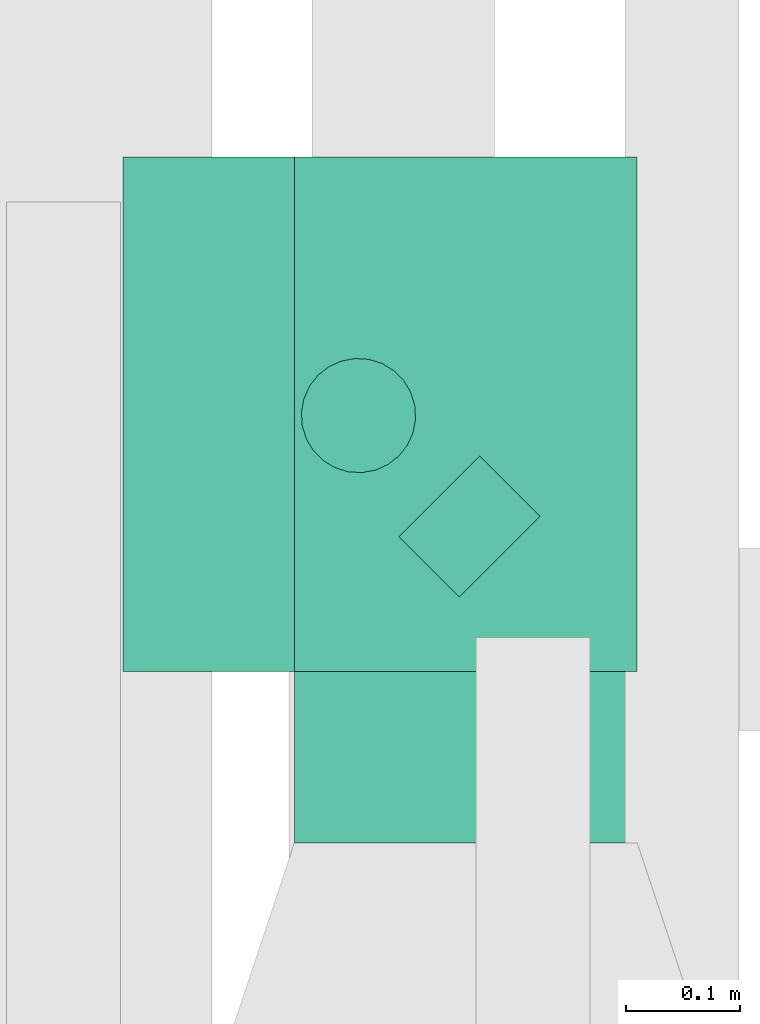
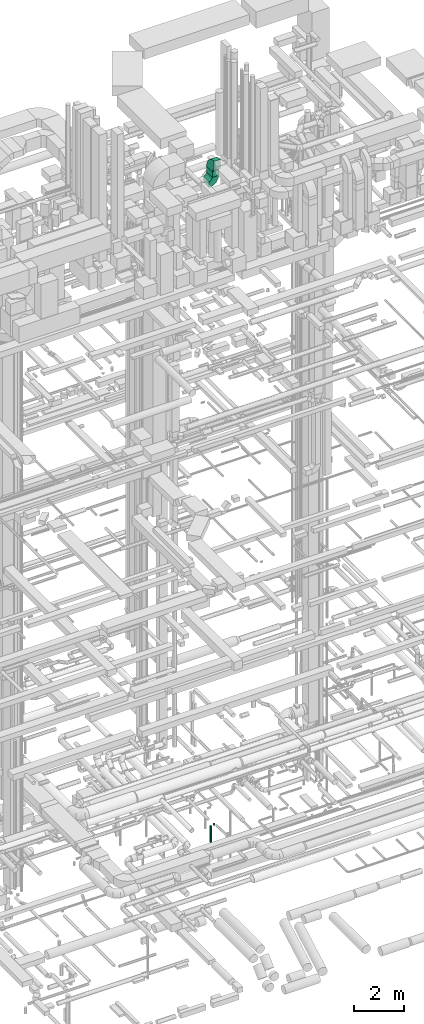
# One storey, part 225 of 337: 3 flow segments, 2 flow fittings.
"""IFC2X3 building model written with IfcOpenShell, lengths in millimetres."""

import ifcopenshell
import ifcopenshell.guid

model = None  # the IFC model being written
_history = None  # IfcOwnerHistory: only IFC2X3 demands one
_inside = {}  # id of a spatial element -> (the spatial element, [elements in it])
_under = {}  # id of a project, library or spatial element -> (it, [spatial elements below it])
_declared = {}  # id of a project -> (the project, [libraries it declares])
_typed = {}  # id of a type object -> (the type object, [elements of that type])
_made_of = {}  # id of a material, layer set ... -> (it, [elements and type objects made of it])


def new_model(schema):
    """Start an empty IFC model of exactly this schema.

    Asked for "IFC4X3", IfcOpenShell would pick the latest addendum, in which some entities
    have other attributes; the version numbers below select the first issue.
    IFC2X3 requires an IfcOwnerHistory on every rooted entity: one is made here for all.
    """
    global model, _history
    if schema == "IFC4X3":
        model = ifcopenshell.file(schema_version=(4, 3, 0, 0))
    else:
        model = ifcopenshell.file(schema=schema)
    _inside.clear()
    _under.clear()
    _declared.clear()
    _typed.clear()
    _made_of.clear()
    _history = None
    if model.schema == "IFC2X3":
        org = make("IfcOrganization", Name="unknown")
        user = make(
            "IfcPersonAndOrganization",
            ThePerson=make("IfcPerson", FamilyName="unknown"),
            TheOrganization=org,
        )
        app = make(
            "IfcApplication",
            ApplicationDeveloper=org,
            Version="unknown",
            ApplicationFullName="unknown",
            ApplicationIdentifier="unknown",
        )
        _history = make(
            "IfcOwnerHistory",
            OwningUser=user,
            OwningApplication=app,
            ChangeAction="ADDED",
            CreationDate=0,
        )
    return model


def make(cls, **values):
    """One entity of the class cls with the attributes given. An attribute that is None is left unset."""
    return model.create_entity(
        cls, **{name: value for name, value in values.items() if value is not None}
    )


def entity(cls, *values):
    """Any entity or typed value of the class cls, its attributes in the order of the schema. None: left unset."""
    e = model.create_entity(cls)
    for i, value in enumerate(values):
        if value is not None:
            e[i] = value
    return e


def rooted(cls, **values):
    """An entity with a GlobalId (a new one), such as an element, a storey or a relation."""
    return make(cls, GlobalId=ifcopenshell.guid.new(), OwnerHistory=_history, **values)


def si_unit(unit_type, name, prefix=None):
    """IfcSIUnit, for example si_unit("LENGTHUNIT", "METRE", prefix="MILLI")."""
    return make("IfcSIUnit", UnitType=unit_type, Prefix=prefix, Name=name)


def converted_unit(unit_type, name, factor, base, dimensions=None, offset=None):
    """IfcConversionBasedUnit, such as the inch: factor (a typed value) times the base unit."""
    return make(
        "IfcConversionBasedUnit"
        if offset is None
        else "IfcConversionBasedUnitWithOffset",
        ConversionOffset=offset,
        Dimensions=None
        if dimensions is None
        else entity("IfcDimensionalExponents", *dimensions),
        UnitType=unit_type,
        Name=name,
        ConversionFactor=make(
            "IfcMeasureWithUnit", ValueComponent=factor, UnitComponent=base
        ),
    )


def derived_unit(unit_type, elements):
    """IfcDerivedUnit: a product of units, each with its exponent."""
    return make(
        "IfcDerivedUnit",
        Elements=[
            make("IfcDerivedUnitElement", Unit=unit, Exponent=power)
            for unit, power in elements
        ],
        UnitType=unit_type,
    )


def assignment(units):
    """IfcUnitAssignment: the units of a project."""
    return None if units is None else make("IfcUnitAssignment", Units=units)


def point(xyz):
    """IfcCartesianPoint."""
    return None if xyz is None else make("IfcCartesianPoint", Coordinates=xyz)


def direction(xyz):
    """IfcDirection."""
    return None if xyz is None else make("IfcDirection", DirectionRatios=xyz)


def frame(location, z_axis=None, x_axis=None):
    """IfcAxis2Placement3D, a coordinate frame: its origin and axes. An axis left out is left unset."""
    return make(
        "IfcAxis2Placement3D",
        Location=point(location),
        Axis=direction(z_axis),
        RefDirection=direction(x_axis),
    )


def frame_2d(location, x_axis=None):
    """IfcAxis2Placement2D, a coordinate frame in the plane: its origin and x axis."""
    return make(
        "IfcAxis2Placement2D", Location=point(location), RefDirection=direction(x_axis)
    )


def origin():
    """The frame at (0, 0, 0) with its axes left unset."""
    return frame((0.0, 0.0, 0.0))


def origin_2d_with_axis():
    """The frame at (0, 0) in the plane with the x axis (1, 0) written out."""
    return frame_2d((0.0, 0.0), x_axis=(1.0, 0.0))


def place(relative_to, where):
    """IfcLocalPlacement: puts the frame where relative to a parent placement (None: the world)."""
    return make(
        "IfcLocalPlacement", PlacementRelTo=relative_to, RelativePlacement=where
    )


def context(
    kind, dimensions, precision=None, world=None, true_north=None, identifier=None
):
    """IfcGeometricRepresentationContext, for example the 3D "Model" context."""
    return make(
        "IfcGeometricRepresentationContext",
        ContextIdentifier=identifier,
        ContextType=kind,
        CoordinateSpaceDimension=dimensions,
        Precision=precision,
        WorldCoordinateSystem=world,
        TrueNorth=true_north,
    )


def subcontext(parent, identifier, kind, view, scale=None):
    """IfcGeometricRepresentationSubContext, for example "Body" below "Model"."""
    return make(
        "IfcGeometricRepresentationSubContext",
        ContextIdentifier=identifier,
        ContextType=kind,
        ParentContext=parent,
        TargetScale=scale,
        TargetView=view,
    )


def project(units=None, contexts=None):
    """IfcProject with its units and contexts."""
    return rooted(
        "IfcProject",
        Name="project",
        RepresentationContexts=contexts,
        UnitsInContext=assignment(units),
    )


def spatial(cls, under=None, at=None, **own):
    """A site, building, storey or space (cls), placed at a placement, below another one or the project."""
    s = rooted(cls, ObjectPlacement=at, **own)
    if under is not None:
        _under.setdefault(under.id(), (under, []))[1].append(s)
    return s


def polyline(points):
    """IfcPolyline through the points."""
    return make("IfcPolyline", Points=[point(p) for p in points])


def circle_curve(where, radius):
    """IfcCircle in the frame where."""
    return make("IfcCircle", Position=where, Radius=radius)


def parameter(value):
    """IfcParameterValue: where a trimmed curve begins or ends, as a parameter of its basis curve."""
    return model.create_entity("IfcParameterValue", value)


def trimmed(basis, trim1, trim2, sense, master):
    """IfcTrimmedCurve: the piece of a basis curve between two trims."""
    return make(
        "IfcTrimmedCurve",
        BasisCurve=basis,
        Trim1=trim1,
        Trim2=trim2,
        SenseAgreement=sense,
        MasterRepresentation=master,
    )


def segment(curve, same_sense, transition):
    """IfcCompositeCurveSegment."""
    return make(
        "IfcCompositeCurveSegment",
        Transition=transition,
        SameSense=same_sense,
        ParentCurve=curve,
    )


def composite_curve(segments, self_intersect=None):
    """IfcCompositeCurve: segments joined end to end."""
    return make("IfcCompositeCurve", Segments=segments, SelfIntersect=self_intersect)


def profile(cls, at=None, kind="AREA", **sizes):
    """A parametric profile (cls). Its sizes go by their IFC names, for example OverallWidth=200.0."""
    return make(cls, ProfileType=kind, Position=at, **sizes)


def rectangle(**sizes):
    """IfcRectangleProfileDef."""
    return profile("IfcRectangleProfileDef", **sizes)


def circle(**sizes):
    """IfcCircleProfileDef."""
    return profile("IfcCircleProfileDef", **sizes)


def outline(outer, holes=None, kind="AREA"):
    """IfcArbitraryClosedProfileDef: a profile drawn as a closed curve; with holes, ...WithVoids."""
    if holes is None:
        return make("IfcArbitraryClosedProfileDef", ProfileType=kind, OuterCurve=outer)
    return make(
        "IfcArbitraryProfileDefWithVoids",
        ProfileType=kind,
        OuterCurve=outer,
        InnerCurves=holes,
    )


def extrude(swept, where, along, depth):
    """IfcExtrudedAreaSolid: the profile swept, set in the frame where, extruded along a direction by depth."""
    return make(
        "IfcExtrudedAreaSolid",
        SweptArea=swept,
        Position=where,
        ExtrudedDirection=direction(along),
        Depth=depth,
    )


def shape(context_of_items, identifier, shape_type, items):
    """IfcShapeRepresentation: the items that make up one representation, for example the "Body"."""
    return make(
        "IfcShapeRepresentation",
        ContextOfItems=context_of_items,
        RepresentationIdentifier=identifier,
        RepresentationType=shape_type,
        Items=items,
    )


def source(mapping_origin, context_of_items, identifier, shape_type, items):
    """IfcRepresentationMap: a shape defined once, which mapped items show again and again."""
    return make(
        "IfcRepresentationMap",
        MappingOrigin=mapping_origin,
        MappedRepresentation=shape(context_of_items, identifier, shape_type, items),
    )


def transform(
    local_origin,
    x_axis=None,
    y_axis=None,
    z_axis=None,
    scale=None,
    scale2=None,
    scale3=None,
    uniform=True,
):
    """IfcCartesianTransformationOperator3D, or its non-uniform kind. x_axis, y_axis, z_axis: its Axis1, 2, 3."""
    if uniform:
        return make(
            "IfcCartesianTransformationOperator3D",
            Axis1=direction(x_axis),
            Axis2=direction(y_axis),
            LocalOrigin=point(local_origin),
            Scale=scale,
            Axis3=direction(z_axis),
        )
    return make(
        "IfcCartesianTransformationOperator3DnonUniform",
        Axis1=direction(x_axis),
        Axis2=direction(y_axis),
        LocalOrigin=point(local_origin),
        Scale=scale,
        Axis3=direction(z_axis),
        Scale2=scale2,
        Scale3=scale3,
    )


def mapped(mapping_source, mapping_target):
    """IfcMappedItem: shows the shape of a source again, moved by a transform."""
    return make(
        "IfcMappedItem", MappingSource=mapping_source, MappingTarget=mapping_target
    )


def material(Name=None, Category=None):
    """IfcMaterial."""
    return make("IfcMaterial", Name=Name, Category=Category)


def made_of(thing, what):
    """Note that an element or type object is made of a material, layer set ...; save() writes the relation."""
    if what is not None:
        _made_of.setdefault(what.id(), (what, []))[1].append(thing)
    return thing


def type_object(cls, material=None, **own):
    """A type object (cls), such as IfcWallType, which elements share."""
    return made_of(rooted(cls, **own), material)


def type_shapes(of_type, sources):
    """Give a type object the sources (RepresentationMaps) that its elements show as mapped items."""
    of_type.RepresentationMaps = sources


def element(
    cls,
    number,
    at=None,
    inside=None,
    cuts=None,
    type_object=None,
    material=None,
    context=None,
    identifier="Body",
    shape_type=None,
    held_by="IfcProductDefinitionShape",
    body=None,
    shapes=None,
    **own,
):
    """One element of the class cls, such as IfcWall. Its Tag is "e" and its number.

    at: its placement. inside: the storey or other place that contains it. cuts: it is an
    opening in that element (IfcRelVoidsElement). A single representation is given by context,
    identifier, shape_type and body (its items); several are given by shapes. held_by: the class
    of the entity that holds the representations. save() writes the other relations.
    """
    e = rooted(cls, Tag="e%d" % number, ObjectPlacement=at, **own)
    if body is not None:
        shapes = [shape(context, identifier, shape_type, body)]
    if shapes is not None:
        e.Representation = make(held_by, Representations=shapes)
    if inside is not None:
        _inside.setdefault(inside.id(), (inside, []))[1].append(e)
    if cuts is not None:
        rooted(
            "IfcRelVoidsElement", RelatingBuildingElement=cuts, RelatedOpeningElement=e
        )
    if type_object is not None:
        _typed.setdefault(type_object.id(), (type_object, []))[1].append(e)
    return made_of(e, material)


def aggregate(whole, parts):
    """IfcRelAggregates: a whole, such as a stair, and the parts it consists of."""
    return rooted("IfcRelAggregates", RelatingObject=whole, RelatedObjects=parts)


def save(model, path):
    """Write the relations noted so far, then the file.

    IfcRelAggregates (storeys below a building ...), IfcRelContainedInSpatialStructure (elements
    in a storey), IfcRelDefinesByType, IfcRelAssociatesMaterial and IfcRelDeclares: one each for
    every whole, place, type object, material and project.
    """
    for whole, parts in _under.values():
        aggregate(whole, parts)
    for where, things in _inside.values():
        rooted(
            "IfcRelContainedInSpatialStructure",
            RelatedElements=things,
            RelatingStructure=where,
        )
    for kind, things in _typed.values():
        rooted("IfcRelDefinesByType", RelatedObjects=things, RelatingType=kind)
    for what, things in _made_of.values():
        rooted("IfcRelAssociatesMaterial", RelatedObjects=things, RelatingMaterial=what)
    for by, libraries in _declared.values():
        rooted("IfcRelDeclares", RelatingContext=by, RelatedDefinitions=libraries)
    model.write(path)


model = new_model("IFC2X3")

# Units and contexts
model_context = context("Model", 3, precision=0.01, world=origin(), true_north=direction((6.12303176911189e-17, 1.0)))
body_context = subcontext(model_context, "Body", "Model", "MODEL_VIEW")
ifc_project = project(units=[si_unit("LENGTHUNIT", "METRE", prefix="MILLI"), si_unit("AREAUNIT", "SQUARE_METRE"), si_unit("VOLUMEUNIT", "CUBIC_METRE"), converted_unit("PLANEANGLEUNIT", "DEGREE", entity("IfcRatioMeasure", 0.0174532925199433), si_unit("PLANEANGLEUNIT", "RADIAN"), dimensions=[0, 0, 0, 0, 0, 0, 0]), si_unit("MASSUNIT", "GRAM", prefix="KILO"), derived_unit("MASSDENSITYUNIT", [(si_unit("MASSUNIT", "GRAM", prefix="KILO"), 1), (si_unit("LENGTHUNIT", "METRE"), -3)]), derived_unit("MOMENTOFINERTIAUNIT", [(si_unit("LENGTHUNIT", "METRE"), 4)]), si_unit("TIMEUNIT", "SECOND"), si_unit("FREQUENCYUNIT", "HERTZ"), si_unit("THERMODYNAMICTEMPERATUREUNIT", "DEGREE_CELSIUS"), derived_unit("THERMALTRANSMITTANCEUNIT", [(si_unit("MASSUNIT", "GRAM", prefix="KILO"), 1), (si_unit("THERMODYNAMICTEMPERATUREUNIT", "KELVIN"), -1), (si_unit("TIMEUNIT", "SECOND"), -3)]), derived_unit("VOLUMETRICFLOWRATEUNIT", [(si_unit("LENGTHUNIT", "METRE"), 3), (si_unit("TIMEUNIT", "SECOND"), -1)]), derived_unit("MASSFLOWRATEUNIT", [(si_unit("MASSUNIT", "GRAM", prefix="KILO"), 1), (si_unit("TIMEUNIT", "SECOND"), -1)]), derived_unit("ROTATIONALFREQUENCYUNIT", [(si_unit("TIMEUNIT", "SECOND"), -1)]), si_unit("ELECTRICCURRENTUNIT", "AMPERE"), si_unit("ELECTRICVOLTAGEUNIT", "VOLT"), si_unit("POWERUNIT", "WATT"), si_unit("FORCEUNIT", "NEWTON", prefix="KILO"), si_unit("ILLUMINANCEUNIT", "LUX"), si_unit("LUMINOUSFLUXUNIT", "LUMEN"), si_unit("LUMINOUSINTENSITYUNIT", "CANDELA"), derived_unit("USERDEFINED", [(si_unit("MASSUNIT", "GRAM", prefix="KILO"), -1), (si_unit("LENGTHUNIT", "METRE"), -2), (si_unit("TIMEUNIT", "SECOND"), 3), (si_unit("LUMINOUSFLUXUNIT", "LUMEN"), 1)]), derived_unit("LINEARVELOCITYUNIT", [(si_unit("LENGTHUNIT", "METRE"), 1), (si_unit("TIMEUNIT", "SECOND"), -1)]), si_unit("PRESSUREUNIT", "PASCAL"), derived_unit("USERDEFINED", [(si_unit("LENGTHUNIT", "METRE"), -2), (si_unit("MASSUNIT", "GRAM", prefix="KILO"), 1), (si_unit("TIMEUNIT", "SECOND"), -2)]), derived_unit("LINEARFORCEUNIT", [(si_unit("MASSUNIT", "GRAM", prefix="KILO"), 1), (si_unit("LENGTHUNIT", "METRE"), 1), (si_unit("TIMEUNIT", "SECOND"), -2), (si_unit("LENGTHUNIT", "METRE"), -1)]), derived_unit("PLANARFORCEUNIT", [(si_unit("MASSUNIT", "GRAM", prefix="KILO"), 1), (si_unit("LENGTHUNIT", "METRE"), 1), (si_unit("TIMEUNIT", "SECOND"), -2), (si_unit("LENGTHUNIT", "METRE"), -2)])], contexts=[model_context])

# Site, building, storey
site_placement = place(None, origin())
site = spatial("IfcSite", under=ifc_project, at=site_placement, CompositionType="ELEMENT")
building_placement = place(site_placement, origin())
building = spatial("IfcBuilding", under=site, at=building_placement, CompositionType="ELEMENT")
storey_placement = place(building_placement, origin())
storey = spatial("IfcBuildingStorey", under=building, at=storey_placement, CompositionType="ELEMENT", Elevation=0.0)

# Flow segments
duct_segment_type_1 = type_object("IfcDuctSegmentType", PredefinedType="NOTDEFINED")
flow_segment_1_placement = place(storey_placement, frame((54238.0, 11049.6, 30900.0)))
element("IfcFlowSegment", 1, at=flow_segment_1_placement, inside=storey, type_object=duct_segment_type_1, context=body_context, shape_type="SweptSolid", body=[
    extrude(rectangle(XDim=450.000000000002, YDim=300.000000000001, at=origin_2d_with_axis()), frame((150.0, 225.0, 0.0), z_axis=(0.0, 0.0, 1.0), x_axis=(0.0, 1.0, 0.0)), (0.0, 0.0, 1.0), 275.00000000008),
])
duct_segment_type_2 = type_object("IfcDuctSegmentType", PredefinedType="NOTDEFINED")
flow_segment_2_placement = place(storey_placement, frame((54327.93, 11113.08, -836.6)))
element("IfcFlowSegment", 2, at=flow_segment_2_placement, inside=storey, type_object=duct_segment_type_2, context=body_context, shape_type="SweptSolid", body=[
    extrude(circle(Radius=50.0, at=origin_2d_with_axis()), frame((36.95, 89.68, 51.6), z_axis=(0.707106781186722, -0.707106781186373, 0.0), x_axis=(0.707106781186373, 0.707106781186722, 0.0)), (0.0, 0.0, 1.0), 74.5745641295053),
])
flow_segment_3_placement = place(storey_placement, frame((54242.58, 11221.88, -1676.49)))
element("IfcFlowSegment", 3, at=flow_segment_3_placement, inside=storey, type_object=duct_segment_type_2, context=body_context, shape_type="SweptSolid", body=[
    extrude(circle(Radius=50.0, at=origin_2d_with_axis()), frame((51.6, 51.6, 0.0), z_axis=(0.0, 0.0, 1.0), x_axis=(-0.707106781186546, 0.707106781186549, 0.0)), (0.0, 0.0, 1.0), 791.48680054773),
])

# Flow fittings
ifc_material = material()
duct_fitting_type_1 = type_object("IfcDuctFittingType", PredefinedType="NOTDEFINED", material=ifc_material)
shared_shape_1 = source(origin(), body_context, "Body", "SweptSolid", [
    extrude(outline(composite_curve([segment(polyline([(-412.5, -187.5), (37.5, -187.5)]), True, "CONTINUOUS"), segment(trimmed(circle_curve(frame_2d((187.5, -187.5), x_axis=(0.0, 1.0)), 150.0), [parameter(0.0)], [parameter(90.0)], True, "PARAMETER"), False, "CONTINUOUS"), segment(polyline([(187.5, -37.5), (187.5, 412.5)]), True, "CONTINUOUS"), segment(trimmed(circle_curve(frame_2d((187.5, -187.5), x_axis=(0.0, 1.0)), 600.0), [parameter(0.0)], [parameter(90.0)], True, "PARAMETER"), True, "CONTINUOUS")], self_intersect=False)), frame((-187.5, 187.5, -150.0), z_axis=(0.0, 0.0, 1.0), x_axis=(-1.0, 0.0, 0.0)), (0.0, 0.0, 1.0), 300.0),
])
type_shapes(duct_fitting_type_1, [shared_shape_1])
flow_fitting_1_placement = place(storey_placement, frame((54388.0, 11274.6, 31550.0), z_axis=(-1.0, 0.0, 0.0), x_axis=(0.0, 1.0, 0.0)))
element("IfcFlowFitting", 4, at=flow_fitting_1_placement, inside=storey, type_object=duct_fitting_type_1, material=ifc_material, context=body_context, shape_type="MappedRepresentation", body=[
    mapped(shared_shape_1, transform((0.0, 0.0, 0.0), scale=1.0)),
])
duct_fitting_type_2 = type_object("IfcDuctFittingType", PredefinedType="NOTDEFINED", material=ifc_material)
shared_shape_2 = source(origin(), body_context, "Body", "SweptSolid", [
    extrude(outline(composite_curve([segment(polyline([(-300.0, -150.0), (0.0, -150.0)]), True, "CONTINUOUS"), segment(trimmed(circle_curve(frame_2d((150.0, -150.0), x_axis=(0.0, 1.0)), 150.0), [parameter(0.0)], [parameter(90.0)], True, "PARAMETER"), False, "CONTINUOUS"), segment(polyline([(150.0, 0.0), (150.0, 300.0)]), True, "CONTINUOUS"), segment(trimmed(circle_curve(frame_2d((150.0, -150.0), x_axis=(0.0, 1.0)), 450.0), [parameter(0.0)], [parameter(90.0000000000001)], True, "PARAMETER"), True, "CONTINUOUS")], self_intersect=False)), frame((-150.0, 150.0, -225.0), z_axis=(0.0, 0.0, 1.0), x_axis=(-1.0, 0.0, 0.0)), (0.0, 0.0, 1.0), 450.0),
])
type_shapes(duct_fitting_type_2, [shared_shape_2])
flow_fitting_2_placement = place(storey_placement, frame((54388.0, 11274.6, 30600.0), z_axis=(0.0, 1.0, 0.0), x_axis=(0.0, 0.0, -1.0)))
element("IfcFlowFitting", 5, at=flow_fitting_2_placement, inside=storey, type_object=duct_fitting_type_2, material=ifc_material, context=body_context, shape_type="MappedRepresentation", body=[
    mapped(shared_shape_2, transform((0.0, 0.0, 0.0), scale=1.0)),
])

save(model, "model.ifc")
